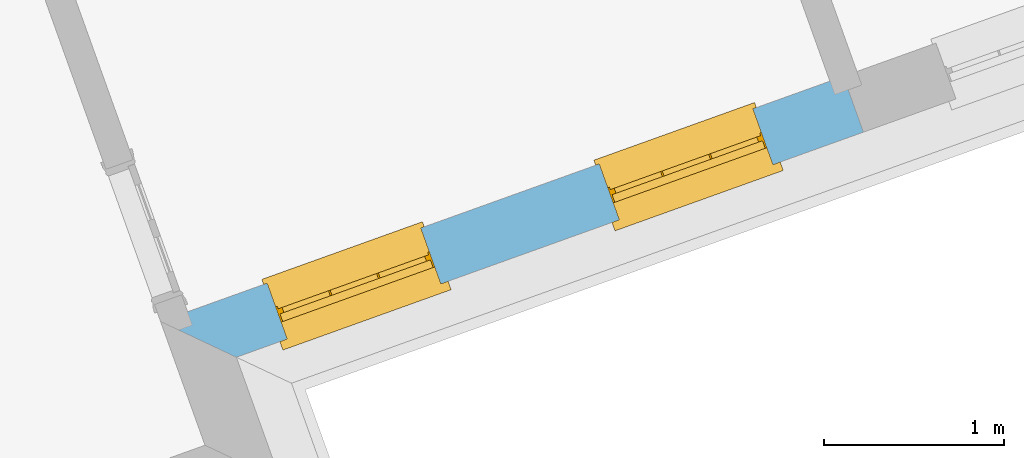
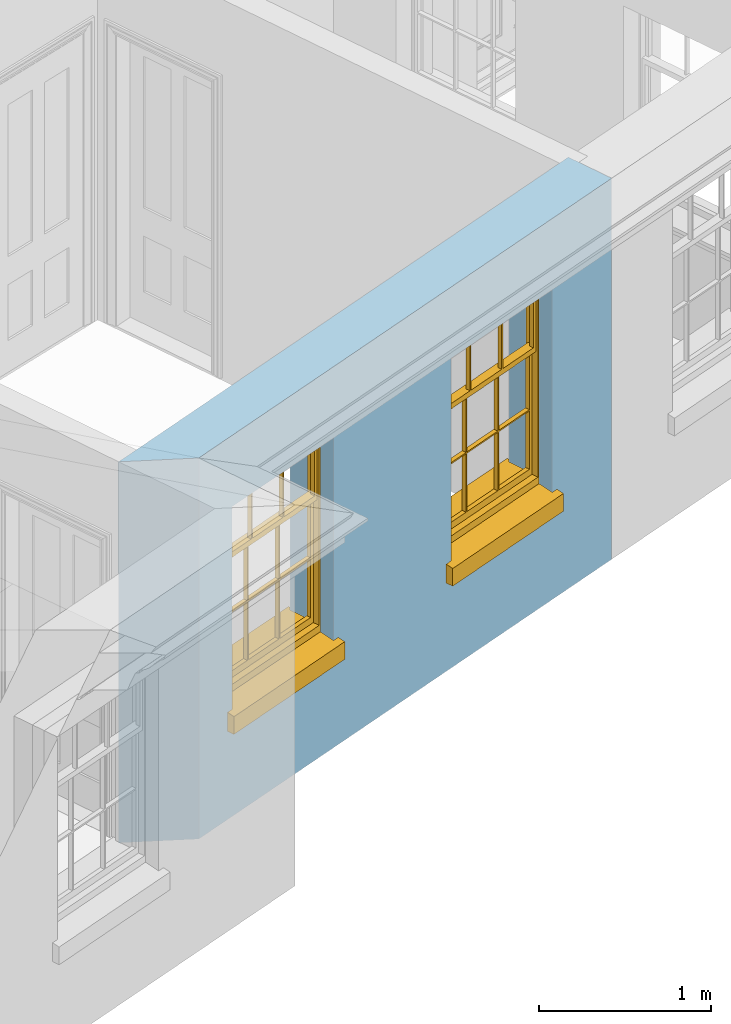
# One storey, part 3 of 10: 2 windows, 2 openings, plus 1 element that does not belong to this part.
"""IFC2X3 building model written with IfcOpenShell, lengths in metres."""

from ifc_helpers import new_model, si_unit, frame, origin, place, context, subcontext, project, spatial, polyline, outline, extrude, faceted_brep, material, layer, layer_set, layer_usage, element, fill, save


model = new_model("IFC2X3")

# Units and contexts
model_context = context("Model", 3, world=origin())
body_context = subcontext(model_context, "Body", "Model", "MODEL_VIEW")
ifc_project = project(units=[si_unit("PLANEANGLEUNIT", "RADIAN"), si_unit("MASSUNIT", "GRAM", prefix="KILO"), si_unit("FORCEUNIT", "NEWTON", prefix="KILO"), si_unit("LENGTHUNIT", "METRE")], contexts=[model_context])

# Site, building, storey
site_placement = place(None, origin())
site = spatial("IfcSite", under=ifc_project, at=site_placement, CompositionType="ELEMENT")
building_placement = place(None, origin())
building = spatial("IfcBuilding", under=site, at=building_placement, Name="Building plot-9", CompositionType="ELEMENT")
storey_placement = place(None, frame((0.0, 0.0, 4.3)))
storey = spatial("IfcBuildingStorey", under=building, at=storey_placement, Name="Floor 1", CompositionType="ELEMENT", Elevation=4.3)

# Wall, openings, windows
ifc_material = material(Name="Masonry")
ifc_layer = layer(ifc_material, 0.33, ventilated=False)
ifc_layer_set = layer_set([ifc_layer], Name="My Wall")
ifc_layer_usage = layer_usage(ifc_layer_set, "AXIS2", "NEGATIVE", 0.08)
wall_placement = place(storey_placement, origin())
wall = element("IfcWallStandardCase", 1, at=wall_placement, inside=storey, material=ifc_layer_usage, Name="exterior", context=body_context, shape_type="SweptSolid", body=[
    extrude(outline(polyline([(33.7689911145764, 14.5518234447509), (34.1910793199225, 14.3527215941627), (37.6825977583454, 15.6060593797825), (37.5711045809664, 15.9166544077497), (33.7689911145764, 14.5518234447509)])), origin(), (0.0, 0.0, 1.0), 2.7),
])
opening_1_placement = place(storey_placement, frame((0.0, 0.0, 0.75)))
opening_1 = element("IfcOpeningElement", 2, at=opening_1_placement, cuts=wall, Name="Opening", ObjectType="Opening", context=body_context, shape_type="SweptSolid", body=[
    extrude(outline(polyline([(34.4734384362563, 14.4540790281435), (35.3299277558022, 14.7615299112188), (35.2184345784233, 15.072124939186), (34.3619452588774, 14.7646740561107), (34.4734384362563, 14.4540790281435)])), origin(), (0.0, 0.0, 1.0), 1.445),
])
opening_2_placement = place(storey_placement, frame((0.0, 0.0, 0.75)))
opening_2 = element("IfcOpeningElement", 3, at=opening_2_placement, cuts=wall, Name="Opening", ObjectType="Opening", context=body_context, shape_type="SweptSolid", body=[
    extrude(outline(polyline([(36.3226486730638, 15.1178833597605), (37.1791379926097, 15.4253342428358), (37.0676448152308, 15.735929270803), (36.2111554956849, 15.4284783877277), (36.3226486730638, 15.1178833597605)])), origin(), (0.0, 0.0, 1.0), 1.445),
])
window_1_placement = place(storey_placement, frame((34.3889739079389, 14.689378291755, 0.75), z_axis=(0.0, 0.0, 1.0), x_axis=(0.856489319545922, 0.307450883075273, 0.0)))
window_1 = element("IfcWindow", 4, at=window_1_placement, inside=storey, Name="circulation outside window", OverallHeight=1.445, OverallWidth=0.91, context=body_context, shape_type="Brep", held_by="IfcProductRepresentation", body=[
    faceted_brep([(0.876875, -0.105, 0.999097), (0.876875, -0.105, 1.411875), (0.9, -0.105, 1.435), (0.033125, -0.105, 1.411875), (0.033125, -0.105, 0.999097), (0.01, -0.105, 1.435), (0.033125, -0.135, 1.411875), (0.01, -0.135, 1.435), (0.033125, -0.135, 0.999097), (0.876875, -0.135, 1.411875), (0.876875, -0.135, 0.999097), (0.9, -0.135, 1.435), (0.033125, -0.105, 0.960972), (0.01, -0.105, 0.960972), (0.033125, -0.105, 0.548195), (0.876875, -0.105, 0.960972), (0.876875, -0.105, 0.548195), (0.9, -0.105, 0.960972), (0.876875, -0.105, 0.538195), (0.876875, -0.105, 0.125417), (0.9, -0.105, 0.077167), (0.033125, -0.105, 0.125417), (0.033125, -0.105, 0.538195), (0.01, -0.105, 0.077167), (0.9, -0.135, 0.960972), (0.01, -0.135, 0.960972), (-0.0425, -0.25, 0.01), (-0.0425, -0.3, 0.001667), (0.0, -0.25, 0.01), (0.9525, -0.25, 0.01), (0.91, -0.25, 0.01), (0.9525, -0.3, 0.001667), (-0.02, 0.08, 0.077167), (0.0, 0.08, 0.077167), (-0.02, 0.11, 0.077167), (0.0, -0.06, 0.077167), (0.01, -0.06, 0.077167), (0.91, -0.06, 0.077167), (0.91, 0.08, 0.077167), (0.9, -0.06, 0.077167), (0.93, 0.08, 0.077167), (0.93, 0.11, 0.077167), (0.01, -0.105, 0.999097), (0.01, -0.075, 0.999097), (0.9, -0.105, 0.999097), (0.9, -0.075, 0.999097), (0.876875, -0.075, 0.125417), (0.876875, -0.075, 0.538195), (0.9, -0.075, 0.077167), (0.876875, -0.075, 0.548195), (0.876875, -0.075, 0.960972), (0.033125, -0.075, 0.125417), (0.01, -0.075, 0.077167), (0.033125, -0.075, 0.538195), (0.033125, -0.075, 0.960972), (0.033125, -0.075, 0.548195), (-0.02, 0.08, 0.052167), (-0.02, 0.11, 0.052167), (0.93, 0.11, 0.052167), (0.93, 0.08, 0.052167), (0.91, 0.08, 0.052167), (0.0, 0.08, 0.052167), (0.91, -0.15, 0.026667), (0.0, -0.15, 0.026667), (-0.0425, -0.3, -0.123333), (0.9525, -0.3, -0.123333), (-0.0425, -0.25, -0.123333), (0.9525, -0.25, -0.123333), (0.01, -0.06, 1.435), (0.9, -0.06, 1.435), (0.0, -0.06, 1.445), (0.91, -0.06, 1.445), (0.01, -0.15, 0.077167), (0.9, -0.15, 0.077167), (0.592292, -0.105, 0.125417), (0.592292, -0.075, 0.125417), (0.317708, -0.075, 0.125417), (0.317708, -0.105, 0.125417), (0.592292, -0.105, 0.548195), (0.317708, -0.105, 0.548195), (0.317708, -0.105, 0.538195), (0.592292, -0.105, 0.538195), (0.592292, -0.075, 0.548195), (0.317708, -0.075, 0.548195), (0.602292, -0.075, 0.548195), (0.602292, -0.105, 0.548195), (0.317708, -0.075, 0.538195), (0.307708, -0.075, 0.125417), (0.307708, -0.075, 0.538195), (0.602292, -0.075, 0.538195), (0.602292, -0.075, 0.125417), (0.592292, -0.075, 0.538195), (0.307708, -0.075, 0.548195), (0.317708, -0.075, 0.960972), (0.307708, -0.075, 0.960972), (0.602292, -0.075, 0.960972), (0.592292, -0.075, 0.960972), (0.307708, -0.105, 0.538195), (0.307708, -0.105, 0.125417), (0.307708, -0.105, 0.548195), (0.307708, -0.105, 0.960972), (0.592292, -0.105, 0.960972), (0.317708, -0.105, 0.960972), (0.602292, -0.105, 0.960972), (0.602292, -0.105, 0.538195), (0.602292, -0.105, 0.125417), (0.317708, -0.135, 1.411875), (0.307708, -0.135, 1.411875), (0.307708, -0.135, 0.999097), (0.317708, -0.135, 0.999097), (0.602292, -0.135, 1.411875), (0.592292, -0.135, 1.411875), (0.592292, -0.135, 0.999097), (0.602292, -0.135, 0.999097), (0.317708, -0.105, 0.999097), (0.307708, -0.105, 0.999097), (0.307708, -0.105, 1.411875), (0.317708, -0.105, 1.411875), (0.602292, -0.105, 0.999097), (0.592292, -0.105, 0.999097), (0.592292, -0.105, 1.411875), (0.602292, -0.105, 1.411875), (0.91, -0.15, 1.445), (0.9, -0.15, 1.435), (0.01, -0.15, 1.435), (0.0, -0.15, 1.445), (0.91, -0.25, 0.0), (0.0, -0.25, 0.0), (0.91, 0.08, 0.0), (0.0, 0.08, 0.0)], [[[0, 1, 2]], [[3, 4, 5]], [[6, 7, 8]], [[9, 10, 11]], [[12, 13, 14]], [[15, 16, 17]], [[18, 19, 20]], [[21, 22, 23]], [[24, 15, 17]], [[13, 12, 25]], [[26, 27, 28]], [[29, 30, 31]], [[32, 33, 34]], [[35, 36, 33]], [[37, 38, 39]], [[40, 41, 38]], [[42, 4, 43]], [[44, 45, 0]], [[46, 47, 48]], [[49, 50, 45]], [[51, 52, 53]], [[54, 55, 43]], [[38, 33, 36, 39]], [[41, 34, 33, 38]], [[56, 32, 34, 57]], [[57, 34, 41, 58]], [[58, 41, 40, 59]], [[57, 58, 60, 61]], [[52, 48, 39, 36]], [[62, 63, 28, 30]], [[27, 31, 30, 28]], [[27, 64, 65, 31]], [[66, 67, 65, 64]], [[2, 5, 68, 69]], [[68, 70, 71, 69]], [[20, 23, 72, 73]], [[73, 72, 63, 62]], [[74, 75, 76, 77]], [[78, 79, 80, 81]], [[78, 82, 83, 79]], [[16, 49, 84, 85]], [[86, 76, 87, 88]], [[89, 90, 75, 91]], [[92, 88, 53, 55]], [[82, 91, 86, 83]], [[93, 83, 92, 94]], [[95, 84, 82, 96]], [[89, 84, 49, 47]], [[97, 88, 87, 98]], [[22, 53, 88, 97]], [[81, 91, 75, 74]], [[80, 86, 91, 81]], [[77, 76, 86, 80]], [[99, 92, 55, 14]], [[100, 94, 92, 99]], [[101, 96, 82, 78]], [[79, 83, 93, 102]], [[85, 84, 95, 103]], [[104, 89, 47, 18]], [[105, 90, 89, 104]], [[104, 18, 16, 85]], [[80, 97, 98, 77]], [[104, 81, 74, 105]], [[103, 101, 78, 85]], [[99, 14, 22, 97]], [[102, 100, 99, 79]], [[106, 107, 108, 109]], [[110, 111, 112, 113]], [[114, 115, 116, 117]], [[118, 119, 120, 121]], [[107, 116, 115, 108]], [[111, 120, 119, 112]], [[109, 114, 117, 106]], [[113, 118, 121, 110]], [[85, 78, 81, 104]], [[84, 89, 91, 82]], [[83, 86, 88, 92]], [[79, 99, 97, 80]], [[109, 112, 119, 114]], [[102, 93, 96, 101]], [[106, 117, 120, 111]], [[98, 87, 51, 21]], [[6, 3, 116, 107]], [[110, 121, 1, 9]], [[19, 46, 90, 105]], [[26, 66, 64, 27]], [[29, 31, 65, 67]], [[25, 24, 112, 109]], [[11, 7, 106, 111]], [[75, 48, 52, 76]], [[43, 45, 96, 93]], [[45, 43, 114, 119]], [[5, 2, 120, 117]], [[24, 25, 102, 101]], [[42, 5, 4]], [[2, 44, 0]], [[49, 45, 48, 47]], [[52, 43, 55, 53]], [[14, 13, 23, 22]], [[20, 17, 16, 18]], [[24, 11, 10]], [[25, 8, 7]], [[8, 4, 3, 6]], [[9, 1, 0, 10]], [[15, 50, 49, 16]], [[18, 47, 46, 19]], [[21, 51, 53, 22]], [[14, 55, 54, 12]], [[44, 2, 69, 45]], [[68, 5, 42, 43]], [[36, 35, 70, 68]], [[39, 69, 71, 37]], [[62, 122, 123, 73]], [[63, 72, 124, 125]], [[8, 108, 115, 4]], [[113, 10, 0, 118]], [[94, 100, 12, 54]], [[17, 20, 73, 24]], [[72, 23, 13, 25]], [[52, 36, 68, 43]], [[69, 39, 48, 45]], [[11, 24, 73, 123]], [[7, 124, 72, 25]], [[23, 77, 98]], [[98, 21, 23]], [[105, 74, 20]], [[20, 19, 105]], [[20, 74, 77, 23]], [[113, 112, 24]], [[24, 10, 113]], [[25, 109, 108]], [[108, 8, 25]], [[110, 9, 11]], [[11, 111, 110]], [[7, 6, 107]], [[107, 106, 7]], [[5, 117, 116]], [[116, 3, 5]], [[121, 120, 2]], [[2, 1, 121]], [[11, 123, 124, 7]], [[122, 125, 124, 123]], [[43, 93, 94]], [[94, 54, 43]], [[96, 45, 95]], [[50, 95, 45]], [[15, 103, 95, 50]], [[48, 75, 90]], [[90, 46, 48]], [[87, 76, 52]], [[52, 51, 87]], [[103, 15, 24]], [[24, 101, 103]], [[100, 102, 25]], [[25, 12, 100]], [[115, 114, 43]], [[43, 4, 115]], [[118, 0, 45]], [[45, 119, 118]], [[71, 70, 125, 122]], [[70, 35, 63, 125]], [[122, 62, 37, 71]], [[126, 67, 66, 127]], [[60, 58, 59]], [[38, 60, 59, 40]], [[61, 56, 57]], [[32, 56, 61, 33]], [[61, 60, 128, 129]], [[62, 60, 38, 37]], [[126, 128, 60, 62]], [[33, 61, 63, 35]], [[61, 129, 127, 63]], [[128, 126, 127, 129]], [[28, 127, 66, 26]], [[63, 127, 28]], [[29, 67, 126, 30]], [[30, 126, 62]]]),
])
fill(opening_1, window_1)
window_2_placement = place(storey_placement, frame((36.2381841447464, 15.3531826233721, 0.75), z_axis=(0.0, 0.0, 1.0), x_axis=(0.856489319545915, 0.307450883075273, 0.0)))
window_2 = element("IfcWindow", 5, at=window_2_placement, inside=storey, Name="circulation outside window", OverallHeight=1.445, OverallWidth=0.91, context=body_context, shape_type="Brep", held_by="IfcProductRepresentation", body=[
    faceted_brep([(0.876875, -0.105, 0.999097), (0.876875, -0.105, 1.411875), (0.9, -0.105, 1.435), (0.033125, -0.105, 1.411875), (0.033125, -0.105, 0.999097), (0.01, -0.105, 1.435), (0.033125, -0.135, 1.411875), (0.01, -0.135, 1.435), (0.033125, -0.135, 0.999097), (0.876875, -0.135, 1.411875), (0.876875, -0.135, 0.999097), (0.9, -0.135, 1.435), (0.033125, -0.105, 0.960972), (0.01, -0.105, 0.960972), (0.033125, -0.105, 0.548195), (0.876875, -0.105, 0.960972), (0.876875, -0.105, 0.548195), (0.9, -0.105, 0.960972), (0.876875, -0.105, 0.538195), (0.876875, -0.105, 0.125417), (0.9, -0.105, 0.077167), (0.033125, -0.105, 0.125417), (0.033125, -0.105, 0.538195), (0.01, -0.105, 0.077167), (0.9, -0.135, 0.960972), (0.01, -0.135, 0.960972), (-0.0425, -0.25, 0.01), (-0.0425, -0.3, 0.001667), (0.0, -0.25, 0.01), (0.9525, -0.25, 0.01), (0.91, -0.25, 0.01), (0.9525, -0.3, 0.001667), (-0.02, 0.08, 0.077167), (0.0, 0.08, 0.077167), (-0.02, 0.11, 0.077167), (0.0, -0.06, 0.077167), (0.01, -0.06, 0.077167), (0.91, -0.06, 0.077167), (0.91, 0.08, 0.077167), (0.9, -0.06, 0.077167), (0.93, 0.08, 0.077167), (0.93, 0.11, 0.077167), (0.01, -0.105, 0.999097), (0.01, -0.075, 0.999097), (0.9, -0.105, 0.999097), (0.9, -0.075, 0.999097), (0.876875, -0.075, 0.125417), (0.876875, -0.075, 0.538195), (0.9, -0.075, 0.077167), (0.876875, -0.075, 0.548195), (0.876875, -0.075, 0.960972), (0.033125, -0.075, 0.125417), (0.01, -0.075, 0.077167), (0.033125, -0.075, 0.538195), (0.033125, -0.075, 0.960972), (0.033125, -0.075, 0.548195), (-0.02, 0.08, 0.052167), (-0.02, 0.11, 0.052167), (0.93, 0.11, 0.052167), (0.93, 0.08, 0.052167), (0.91, 0.08, 0.052167), (0.0, 0.08, 0.052167), (0.91, -0.15, 0.026667), (0.0, -0.15, 0.026667), (-0.0425, -0.3, -0.123333), (0.9525, -0.3, -0.123333), (-0.0425, -0.25, -0.123333), (0.9525, -0.25, -0.123333), (0.01, -0.06, 1.435), (0.9, -0.06, 1.435), (0.0, -0.06, 1.445), (0.91, -0.06, 1.445), (0.01, -0.15, 0.077167), (0.9, -0.15, 0.077167), (0.592292, -0.105, 0.125417), (0.592292, -0.075, 0.125417), (0.317708, -0.075, 0.125417), (0.317708, -0.105, 0.125417), (0.592292, -0.105, 0.548195), (0.317708, -0.105, 0.548195), (0.317708, -0.105, 0.538195), (0.592292, -0.105, 0.538195), (0.592292, -0.075, 0.548195), (0.317708, -0.075, 0.548195), (0.602292, -0.075, 0.548195), (0.602292, -0.105, 0.548195), (0.317708, -0.075, 0.538195), (0.307708, -0.075, 0.125417), (0.307708, -0.075, 0.538195), (0.602292, -0.075, 0.538195), (0.602292, -0.075, 0.125417), (0.592292, -0.075, 0.538195), (0.307708, -0.075, 0.548195), (0.317708, -0.075, 0.960972), (0.307708, -0.075, 0.960972), (0.602292, -0.075, 0.960972), (0.592292, -0.075, 0.960972), (0.307708, -0.105, 0.538195), (0.307708, -0.105, 0.125417), (0.307708, -0.105, 0.548195), (0.307708, -0.105, 0.960972), (0.592292, -0.105, 0.960972), (0.317708, -0.105, 0.960972), (0.602292, -0.105, 0.960972), (0.602292, -0.105, 0.538195), (0.602292, -0.105, 0.125417), (0.317708, -0.135, 1.411875), (0.307708, -0.135, 1.411875), (0.307708, -0.135, 0.999097), (0.317708, -0.135, 0.999097), (0.602292, -0.135, 1.411875), (0.592292, -0.135, 1.411875), (0.592292, -0.135, 0.999097), (0.602292, -0.135, 0.999097), (0.317708, -0.105, 0.999097), (0.307708, -0.105, 0.999097), (0.307708, -0.105, 1.411875), (0.317708, -0.105, 1.411875), (0.602292, -0.105, 0.999097), (0.592292, -0.105, 0.999097), (0.592292, -0.105, 1.411875), (0.602292, -0.105, 1.411875), (0.91, -0.15, 1.445), (0.9, -0.15, 1.435), (0.01, -0.15, 1.435), (0.0, -0.15, 1.445), (0.91, -0.25, 0.0), (0.0, -0.25, 0.0), (0.91, 0.08, 0.0), (0.0, 0.08, 0.0)], [[[0, 1, 2]], [[3, 4, 5]], [[6, 7, 8]], [[9, 10, 11]], [[12, 13, 14]], [[15, 16, 17]], [[18, 19, 20]], [[21, 22, 23]], [[24, 15, 17]], [[13, 12, 25]], [[26, 27, 28]], [[29, 30, 31]], [[32, 33, 34]], [[35, 36, 33]], [[37, 38, 39]], [[40, 41, 38]], [[42, 4, 43]], [[44, 45, 0]], [[46, 47, 48]], [[49, 50, 45]], [[51, 52, 53]], [[54, 55, 43]], [[38, 33, 36, 39]], [[41, 34, 33, 38]], [[56, 32, 34, 57]], [[57, 34, 41, 58]], [[58, 41, 40, 59]], [[57, 58, 60, 61]], [[52, 48, 39, 36]], [[62, 63, 28, 30]], [[27, 31, 30, 28]], [[27, 64, 65, 31]], [[66, 67, 65, 64]], [[2, 5, 68, 69]], [[68, 70, 71, 69]], [[20, 23, 72, 73]], [[73, 72, 63, 62]], [[74, 75, 76, 77]], [[78, 79, 80, 81]], [[78, 82, 83, 79]], [[16, 49, 84, 85]], [[86, 76, 87, 88]], [[89, 90, 75, 91]], [[92, 88, 53, 55]], [[82, 91, 86, 83]], [[93, 83, 92, 94]], [[95, 84, 82, 96]], [[89, 84, 49, 47]], [[97, 88, 87, 98]], [[22, 53, 88, 97]], [[81, 91, 75, 74]], [[80, 86, 91, 81]], [[77, 76, 86, 80]], [[99, 92, 55, 14]], [[100, 94, 92, 99]], [[101, 96, 82, 78]], [[79, 83, 93, 102]], [[85, 84, 95, 103]], [[104, 89, 47, 18]], [[105, 90, 89, 104]], [[104, 18, 16, 85]], [[80, 97, 98, 77]], [[104, 81, 74, 105]], [[103, 101, 78, 85]], [[99, 14, 22, 97]], [[102, 100, 99, 79]], [[106, 107, 108, 109]], [[110, 111, 112, 113]], [[114, 115, 116, 117]], [[118, 119, 120, 121]], [[107, 116, 115, 108]], [[111, 120, 119, 112]], [[109, 114, 117, 106]], [[113, 118, 121, 110]], [[85, 78, 81, 104]], [[84, 89, 91, 82]], [[83, 86, 88, 92]], [[79, 99, 97, 80]], [[109, 112, 119, 114]], [[102, 93, 96, 101]], [[106, 117, 120, 111]], [[98, 87, 51, 21]], [[6, 3, 116, 107]], [[110, 121, 1, 9]], [[19, 46, 90, 105]], [[26, 66, 64, 27]], [[29, 31, 65, 67]], [[25, 24, 112, 109]], [[11, 7, 106, 111]], [[75, 48, 52, 76]], [[43, 45, 96, 93]], [[45, 43, 114, 119]], [[5, 2, 120, 117]], [[24, 25, 102, 101]], [[42, 5, 4]], [[2, 44, 0]], [[49, 45, 48, 47]], [[52, 43, 55, 53]], [[14, 13, 23, 22]], [[20, 17, 16, 18]], [[24, 11, 10]], [[25, 8, 7]], [[8, 4, 3, 6]], [[9, 1, 0, 10]], [[15, 50, 49, 16]], [[18, 47, 46, 19]], [[21, 51, 53, 22]], [[14, 55, 54, 12]], [[44, 2, 69, 45]], [[68, 5, 42, 43]], [[36, 35, 70, 68]], [[39, 69, 71, 37]], [[62, 122, 123, 73]], [[63, 72, 124, 125]], [[8, 108, 115, 4]], [[113, 10, 0, 118]], [[94, 100, 12, 54]], [[17, 20, 73, 24]], [[72, 23, 13, 25]], [[52, 36, 68, 43]], [[69, 39, 48, 45]], [[11, 24, 73, 123]], [[7, 124, 72, 25]], [[23, 77, 98]], [[98, 21, 23]], [[105, 74, 20]], [[20, 19, 105]], [[20, 74, 77, 23]], [[113, 112, 24]], [[24, 10, 113]], [[25, 109, 108]], [[108, 8, 25]], [[110, 9, 11]], [[11, 111, 110]], [[7, 6, 107]], [[107, 106, 7]], [[5, 117, 116]], [[116, 3, 5]], [[121, 120, 2]], [[2, 1, 121]], [[11, 123, 124, 7]], [[122, 125, 124, 123]], [[43, 93, 94]], [[94, 54, 43]], [[96, 45, 95]], [[50, 95, 45]], [[15, 103, 95, 50]], [[48, 75, 90]], [[90, 46, 48]], [[87, 76, 52]], [[52, 51, 87]], [[103, 15, 24]], [[24, 101, 103]], [[100, 102, 25]], [[25, 12, 100]], [[115, 114, 43]], [[43, 4, 115]], [[118, 0, 45]], [[45, 119, 118]], [[71, 70, 125, 122]], [[70, 35, 63, 125]], [[122, 62, 37, 71]], [[126, 67, 66, 127]], [[60, 58, 59]], [[38, 60, 59, 40]], [[61, 56, 57]], [[32, 56, 61, 33]], [[61, 60, 128, 129]], [[62, 60, 38, 37]], [[126, 128, 60, 62]], [[33, 61, 63, 35]], [[61, 129, 127, 63]], [[128, 126, 127, 129]], [[28, 127, 66, 26]], [[63, 127, 28]], [[29, 67, 126, 30]], [[30, 126, 62]]]),
])
fill(opening_2, window_2)

save(model, "model.ifc")
